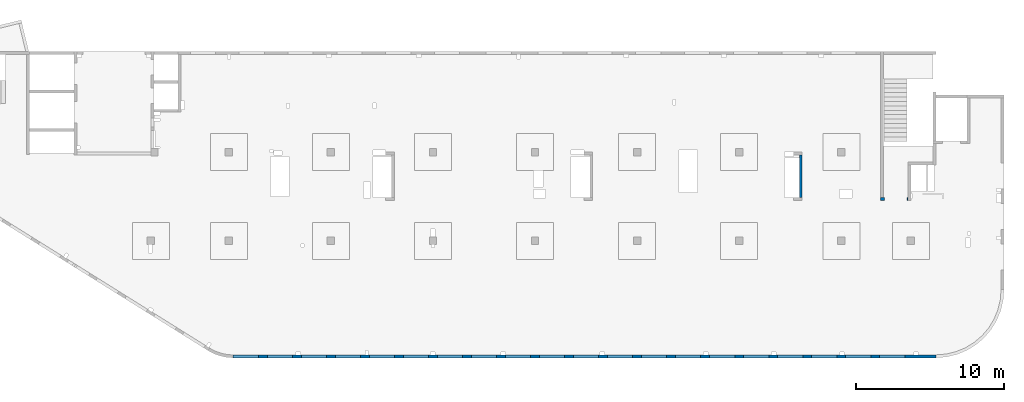
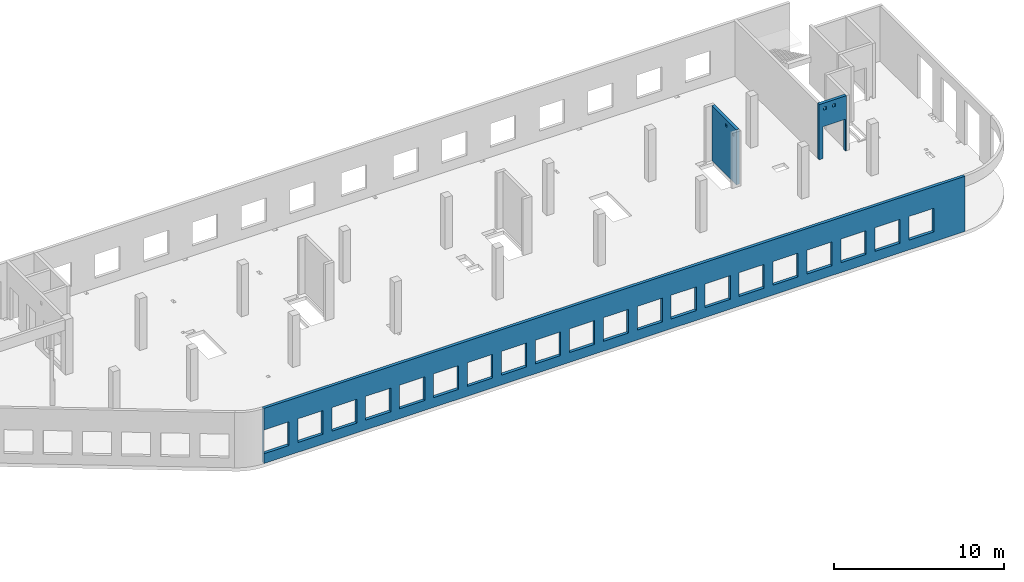
# One storey, part 6 of 7: 3 walls, 25 openings.
"""IFC4 building model written with IfcOpenShell, lengths in millimetres."""

from ifc_helpers import new_model, entity, si_unit, converted_unit, derived_unit, direction, frame, origin, place, context, subcontext, project, spatial, indexed_curve, outline, extrude, polygons, material, type_object, element, save


model = new_model("IFC4")

# Units and contexts
model_context = context("Model", 3, precision=0.01, world=origin(), true_north=direction((6.12303176911189e-17, 1.0)))
plan_context = context("Plan", 3, precision=0.01, world=origin(), true_north=direction((6.12303176911189e-17, 1.0)))
body_context = subcontext(model_context, "Body", "Model", "MODEL_VIEW")
ifc_project = project(units=[si_unit("LENGTHUNIT", "METRE", prefix="MILLI"), si_unit("AREAUNIT", "SQUARE_METRE"), si_unit("VOLUMEUNIT", "CUBIC_METRE"), converted_unit("PLANEANGLEUNIT", "DEGREE", entity("IfcRatioMeasure", 0.0174532925199433), si_unit("PLANEANGLEUNIT", "RADIAN"), dimensions=[0, 0, 0, 0, 0, 0, 0]), si_unit("MASSUNIT", "GRAM", prefix="KILO"), derived_unit("MASSDENSITYUNIT", [(si_unit("MASSUNIT", "GRAM", prefix="KILO"), 1), (si_unit("LENGTHUNIT", "METRE"), -3)]), derived_unit("MOMENTOFINERTIAUNIT", [(si_unit("LENGTHUNIT", "METRE"), 4)]), si_unit("TIMEUNIT", "SECOND"), si_unit("FREQUENCYUNIT", "HERTZ"), si_unit("THERMODYNAMICTEMPERATUREUNIT", "DEGREE_CELSIUS"), derived_unit("THERMALTRANSMITTANCEUNIT", [(si_unit("MASSUNIT", "GRAM", prefix="KILO"), 1), (si_unit("THERMODYNAMICTEMPERATUREUNIT", "KELVIN"), -1), (si_unit("TIMEUNIT", "SECOND"), -3)]), derived_unit("VOLUMETRICFLOWRATEUNIT", [(si_unit("LENGTHUNIT", "METRE"), 3), (si_unit("TIMEUNIT", "SECOND"), -1)]), derived_unit("MASSFLOWRATEUNIT", [(si_unit("MASSUNIT", "GRAM", prefix="KILO"), 1), (si_unit("TIMEUNIT", "SECOND"), -1)]), derived_unit("ROTATIONALFREQUENCYUNIT", [(si_unit("TIMEUNIT", "SECOND"), -1)]), si_unit("ELECTRICCURRENTUNIT", "AMPERE"), si_unit("ELECTRICVOLTAGEUNIT", "VOLT"), si_unit("POWERUNIT", "WATT"), si_unit("FORCEUNIT", "NEWTON", prefix="KILO"), si_unit("ILLUMINANCEUNIT", "LUX"), si_unit("LUMINOUSFLUXUNIT", "LUMEN"), si_unit("LUMINOUSINTENSITYUNIT", "CANDELA"), derived_unit("USERDEFINED", [(si_unit("MASSUNIT", "GRAM", prefix="KILO"), -1), (si_unit("LENGTHUNIT", "METRE"), -2), (si_unit("TIMEUNIT", "SECOND"), 3), (si_unit("LUMINOUSFLUXUNIT", "LUMEN"), 1)]), derived_unit("LINEARVELOCITYUNIT", [(si_unit("LENGTHUNIT", "METRE"), 1), (si_unit("TIMEUNIT", "SECOND"), -1)]), si_unit("PRESSUREUNIT", "PASCAL"), derived_unit("USERDEFINED", [(si_unit("LENGTHUNIT", "METRE"), -2), (si_unit("MASSUNIT", "GRAM", prefix="KILO"), 1), (si_unit("TIMEUNIT", "SECOND"), -2)]), derived_unit("LINEARFORCEUNIT", [(si_unit("MASSUNIT", "GRAM", prefix="KILO"), 1), (si_unit("LENGTHUNIT", "METRE"), 1), (si_unit("TIMEUNIT", "SECOND"), -2), (si_unit("LENGTHUNIT", "METRE"), -1)]), derived_unit("PLANARFORCEUNIT", [(si_unit("MASSUNIT", "GRAM", prefix="KILO"), 1), (si_unit("LENGTHUNIT", "METRE"), 1), (si_unit("TIMEUNIT", "SECOND"), -2), (si_unit("LENGTHUNIT", "METRE"), -2)])], contexts=[model_context, plan_context])

# Site, building, storey
site_placement = place(None, origin())
site = spatial("IfcSite", under=ifc_project, at=site_placement, CompositionType="ELEMENT")
building_placement = place(site_placement, origin())
building = spatial("IfcBuilding", under=site, at=building_placement, CompositionType="ELEMENT")
storey_placement = place(building_placement, frame((0.0, 0.0, 24000.0)))
storey = spatial("IfcBuildingStorey", under=building, at=storey_placement, Name="07", CompositionType="ELEMENT", Elevation=24000.0)

# Wall, openings
ifc_material = material()
wall_type = type_object("IfcWallType", Name=":ADSK_ 25_200", PredefinedType="STANDARD")
wall_1_placement = place(storey_placement, frame((67080.0, 10525.0, -150.0), z_axis=(0.0, 0.0, 1.0), x_axis=(-1.0, 0.0, 0.0)))
wall_1 = element("IfcWall", 1, at=wall_1_placement, inside=storey, type_object=wall_type, material=ifc_material, Name=":ADSK_ 25_200", ObjectType=":ADSK_ 25_200", PredefinedType="NOTDEFINED", context=body_context, shape_type="Tessellation", body=[
    polygons([(1849.99999999999, -100.000000000001, 3950.0), (1650.0, -100.000000000003, 3950.0), (-9.772240076716e-13, -100.000000000001, 3950.0), (-9.772240076716e-13, -100.000000000001, 0.0), (74.9999999999906, -100.000000000001, 0.0), (74.9999999999906, -100.000000000001, 2279.99999999804), (1575.0, -100.000000000001, 2279.99999999804), (1575.0, -100.000000000003, 0.0), (1650.0, -100.000000000003, 0.0), (1849.99999999999, -100.000000000001, 0.0), (744.999999999994, -100.000000000322, 3650.0), (945.000000000001, -100.000000000324, 3650.0), (945.000000000001, -100.000000000324, 3450.00000000001), (744.999999999994, -100.000000000322, 3450.00000000001), (1349.99999999998, -100.000000000322, 3650.0), (1549.99999999999, -100.000000000322, 3650.0), (1549.99999999999, -100.000000000322, 3450.00000000001), (1349.99999999998, -100.000000000322, 3450.00000000001), (-1.61109744921212e-12, 99.9999999999989, 3950.0), (1849.99999999999, 99.9999999999989, 3950.0), (1849.99999999999, 99.9999999999989, 0.0), (1575.0, 99.9999999999968, 0.0), (1575.0, 99.9999999999968, 2279.99999999804), (74.99999999999, 99.9999999999989, 2279.99999999804), (74.99999999999, 99.9999999999989, 0.0), (-1.61109744921212e-12, 99.9999999999989, 0.0), (945.0, 99.9999999999968, 3650.0), (744.999999999994, 99.9999999999989, 3650.0), (744.999999999994, 99.9999999999989, 3450.00000000001), (945.0, 99.9999999999968, 3450.00000000001), (1549.99999999999, 99.9999999999968, 3650.0), (1349.99999999998, 99.9999999999989, 3650.0), (1349.99999999998, 99.9999999999989, 3450.00000000001), (1549.99999999999, 99.9999999999968, 3450.00000000001)], [[[1, 2, 3, 4, 5, 6, 7, 8, 9, 10], [11, 12, 13, 14], [15, 16, 17, 18]], [[19, 20, 21, 22, 23, 24, 25, 26], [27, 28, 29, 30], [31, 32, 33, 34]], [[4, 26, 25, 5]], [[3, 2, 1, 20, 19]], [[4, 3, 19, 26]], [[1, 10, 21, 20]], [[12, 11, 28, 27]], [[12, 27, 30, 13]], [[13, 30, 29, 14]], [[28, 11, 14, 29]], [[16, 15, 32, 31]], [[16, 31, 34, 17]], [[17, 34, 33, 18]], [[32, 15, 18, 33]], [[6, 24, 23, 7]], [[7, 23, 22, 8]], [[24, 6, 5, 25]], [[21, 10, 9, 8, 22]]], closed=True),
])
placement_1 = place(wall_1_placement, frame((67080.0, 10525.0, 150.0), z_axis=(0.0, 0.0, 1.0), x_axis=(-1.0, 0.0, 0.0)))
element("IfcOpeningElement", 2, at=placement_1, cuts=wall_1, Name=":ADSK_ 25_200", PredefinedType="OPENING", context=body_context, shape_type="SweptSolid", body=[
    extrude(outline(indexed_curve([(-750.000000000003, -1139.99999999902), (749.999999999994, -1139.99999999902), (749.999999999994, 1139.99999999902), (-750.000000000003, 1139.99999999902), (-750.000000000003, -1139.99999999902)], self_intersect=False)), frame((66255.0, 10725.0, 990.0), z_axis=(0.0, -1.0, 0.0), x_axis=(-1.0, 0.0, 0.0)), (0.0, 0.0, 1.0), 400.000000001943),
])
element("IfcOpeningElement", 3, at=placement_1, cuts=wall_1, Name=":ADSK_ 25_200", PredefinedType="OPENING", context=body_context, shape_type="SweptSolid", body=[
    extrude(outline(indexed_curve([(-99.9999999999946, -99.9999999999946), (100.000000000003, -99.9999999999946), (100.000000000003, 99.9999999999903), (-99.9999999999946, 99.9999999999903), (-99.9999999999946, -99.9999999999946)], self_intersect=False)), frame((65630.0, 10625.0, 3400.0), z_axis=(0.0, -1.0, 0.0), x_axis=(-1.0, 0.0, 0.0)), (0.0, 0.0, 1.0), 200.000000000962),
])
element("IfcOpeningElement", 4, at=placement_1, cuts=wall_1, Name=":ADSK_ 25_200", PredefinedType="OPENING", context=body_context, shape_type="SweptSolid", body=[
    extrude(outline(indexed_curve([(-100.000000000003, -99.9999999999946), (99.9999999999946, -99.9999999999946), (99.9999999999946, 99.9999999999903), (-100.000000000003, 99.9999999999903), (-100.000000000003, -99.9999999999946)], self_intersect=False)), frame((66235.0, 10625.0, 3400.0), z_axis=(0.0, -1.0, 0.0), x_axis=(-1.0, 0.0, 0.0)), (0.0, 0.0, 1.0), 200.000000000962),
])

wall_2_placement = place(storey_placement, frame((68970.0, -100.0, -150.0), z_axis=(0.0, 0.0, 1.0), x_axis=(-1.0, 0.0, 0.0)))
wall_2 = element("IfcWall", 5, at=wall_2_placement, inside=storey, type_object=wall_type, material=ifc_material, Name=":ADSK_ 25_200", ObjectType=":ADSK_ 25_200", PredefinedType="NOTDEFINED", context=body_context, shape_type="Tessellation", body=[
    polygons([(8.66293717728731e-12, -100.0, 0.0), (47510.4829306172, -100.0, 0.0), (47510.4829306172, -100.0, 3950.0), (8.66293717728731e-12, -100.0, 3950.0), (1.42900165493394e-19, -100.0, 3200.0), (45800.0, -100.000000000321, 2400.0), (47500.0, -100.000000000321, 2400.0), (47500.0, -100.000000000321, 700.000000000014), (45800.0, -100.000000000321, 700.000000000014), (43500.0, -100.000000000321, 2400.0), (45200.0, -100.000000000321, 2400.0), (45200.0, -100.000000000321, 700.00000000001), (43500.0, -100.000000000321, 700.00000000001), (41200.0, -100.000000000321, 2400.0), (42900.0, -100.000000000321, 2400.0), (42900.0, -100.000000000321, 700.00000000001), (41200.0, -100.000000000321, 700.00000000001), (38900.0, -100.000000000321, 2400.0), (40600.0, -100.000000000321, 2400.0), (40600.0, -100.000000000321, 700.00000000001), (38900.0, -100.000000000321, 700.00000000001), (36600.0, -100.000000000321, 2400.0), (38300.0, -100.000000000321, 2400.0), (38300.0, -100.000000000321, 700.00000000001), (36600.0, -100.000000000321, 700.00000000001), (34300.0, -100.000000000321, 2400.0), (36000.0, -100.000000000321, 2400.0), (36000.0, -100.000000000321, 700.00000000001), (34300.0, -100.000000000321, 700.00000000001), (32000.0, -100.000000000321, 2400.0), (33700.0, -100.000000000321, 2400.0), (33700.0, -100.000000000321, 700.00000000001), (32000.0, -100.000000000321, 700.00000000001), (29700.0, -100.000000000321, 2400.0), (31400.0, -100.000000000321, 2400.0), (31400.0, -100.000000000321, 700.00000000001), (29700.0, -100.000000000321, 700.00000000001), (27400.0, -100.000000000321, 2400.0), (29100.0, -100.000000000321, 2400.0), (29100.0, -100.000000000321, 700.00000000001), (27400.0, -100.000000000321, 700.00000000001), (25100.0, -100.000000000321, 2400.0), (26800.0, -100.000000000321, 2400.0), (26800.0, -100.000000000321, 700.00000000001), (25100.0, -100.000000000321, 700.00000000001), (22800.0, -100.000000000321, 2400.0), (24500.0, -100.000000000321, 2400.0), (24500.0, -100.000000000321, 700.00000000001), (22800.0, -100.000000000321, 700.00000000001), (20500.0, -100.000000000321, 2400.0), (22200.0, -100.000000000321, 2400.0), (22200.0, -100.000000000321, 700.00000000001), (20500.0, -100.000000000321, 700.00000000001), (18200.0, -100.000000000321, 2400.0), (19900.0, -100.000000000321, 2400.0), (19900.0, -100.000000000321, 700.00000000001), (18200.0, -100.000000000321, 700.00000000001), (15900.0, -100.000000000321, 2400.0), (17600.0, -100.000000000321, 2400.0), (17600.0, -100.000000000321, 700.00000000001), (15900.0, -100.000000000321, 700.00000000001), (13600.0, -100.000000000321, 2400.0), (15300.0, -100.000000000321, 2400.0), (15300.0, -100.000000000321, 700.00000000001), (13600.0, -100.000000000321, 700.00000000001), (11300.0, -100.000000000321, 2400.0), (13000.0, -100.000000000321, 2400.0), (13000.0, -100.000000000321, 700.00000000001), (11300.0, -100.000000000321, 700.00000000001), (8999.99999999998, -100.000000000321, 2400.0), (10700.0, -100.000000000321, 2400.0), (10700.0, -100.000000000321, 700.00000000001), (8999.99999999998, -100.000000000321, 700.00000000001), (6699.99999999998, -100.000000000321, 2400.0), (8399.99999999997, -100.000000000321, 2400.0), (8399.99999999997, -100.000000000321, 700.00000000001), (6699.99999999998, -100.000000000321, 700.00000000001), (4399.99999999998, -100.000000000321, 2400.0), (6099.99999999997, -100.000000000321, 2400.0), (6099.99999999997, -100.000000000321, 700.00000000001), (4399.99999999998, -100.000000000321, 700.00000000001), (2099.99999999998, -100.000000000321, 2400.0), (3799.99999999998, -100.000000000321, 2400.0), (3799.99999999998, -100.000000000321, 700.00000000001), (2099.99999999998, -100.000000000321, 700.00000000001), (47510.4829306172, 100.0, 0.0), (8.01671852045731e-12, 100.0, 0.0), (-6.46218513929826e-13, 100.0, 3200.0), (8.01671852045731e-12, 100.0, 3950.0), (47510.4829306172, 100.0, 3950.0), (47500.0, 100.0, 2400.0), (45800.0, 100.0, 2400.0), (45800.0, 100.0, 700.00000000001), (47500.0, 100.0, 700.00000000001), (45200.0, 100.0, 2400.0), (43500.0, 100.0, 2400.0), (43500.0, 100.0, 700.00000000001), (45200.0, 100.0, 700.00000000001), (42900.0, 100.0, 2400.0), (41200.0, 100.0, 2400.0), (41200.0, 100.0, 700.00000000001), (42900.0, 100.0, 700.00000000001), (40600.0, 100.0, 2400.0), (38900.0, 100.0, 2400.0), (38900.0, 100.0, 700.00000000001), (40600.0, 100.0, 700.00000000001), (38300.0, 100.0, 2400.0), (36600.0, 100.0, 2400.0), (36600.0, 100.0, 700.00000000001), (38300.0, 100.0, 700.00000000001), (36000.0, 100.0, 2400.0), (34300.0, 100.0, 2400.0), (34300.0, 100.0, 700.00000000001), (36000.0, 100.0, 700.00000000001), (33700.0, 100.0, 2400.0), (32000.0, 100.0, 2400.0), (32000.0, 100.0, 700.00000000001), (33700.0, 100.0, 700.00000000001), (31400.0, 100.0, 2400.0), (29700.0, 100.0, 2400.0), (29700.0, 100.0, 700.00000000001), (31400.0, 100.0, 700.00000000001), (29100.0, 100.0, 2400.0), (27400.0, 100.0, 2400.0), (27400.0, 100.0, 700.00000000001), (29100.0, 100.0, 700.00000000001), (26800.0, 100.0, 2400.0), (25100.0, 100.0, 2400.0), (25100.0, 100.0, 700.00000000001), (26800.0, 100.0, 700.00000000001), (24500.0, 100.0, 2400.0), (22800.0, 100.0, 2400.0), (22800.0, 100.0, 700.00000000001), (24500.0, 100.0, 700.00000000001), (22200.0, 100.0, 2400.0), (20500.0, 100.0, 2400.0), (20500.0, 100.0, 700.00000000001), (22200.0, 100.0, 700.00000000001), (19900.0, 100.0, 2400.0), (18200.0, 100.0, 2400.0), (18200.0, 100.0, 700.00000000001), (19900.0, 100.0, 700.00000000001), (17600.0, 100.0, 2400.0), (15900.0, 100.0, 2400.0), (15900.0, 100.0, 700.00000000001), (17600.0, 100.0, 700.00000000001), (15300.0, 100.0, 2400.0), (13600.0, 100.0, 2400.0), (13600.0, 100.0, 700.00000000001), (15300.0, 100.0, 700.00000000001), (13000.0, 100.0, 2400.0), (11300.0, 100.0, 2400.0), (11300.0, 100.0, 700.00000000001), (13000.0, 100.0, 700.00000000001), (10700.0, 100.0, 2400.0), (8999.99999999998, 100.0, 2400.0), (8999.99999999998, 100.0, 700.00000000001), (10700.0, 100.0, 700.00000000001), (8399.99999999997, 100.0, 2400.0), (6699.99999999997, 100.0, 2400.0), (6699.99999999997, 100.0, 700.00000000001), (8399.99999999997, 100.0, 700.00000000001), (6099.99999999997, 100.0, 2400.0), (4399.99999999998, 100.0, 2400.0), (4399.99999999998, 100.0, 700.00000000001), (6099.99999999997, 100.0, 700.00000000001), (3799.99999999998, 100.0, 2400.0), (2099.99999999998, 100.0, 2400.0), (2099.99999999998, 100.0, 700.00000000001), (3799.99999999998, 100.0, 700.00000000001)], [[[1, 2, 3, 4, 5], [6, 7, 8, 9], [10, 11, 12, 13], [14, 15, 16, 17], [18, 19, 20, 21], [22, 23, 24, 25], [26, 27, 28, 29], [30, 31, 32, 33], [34, 35, 36, 37], [38, 39, 40, 41], [42, 43, 44, 45], [46, 47, 48, 49], [50, 51, 52, 53], [54, 55, 56, 57], [58, 59, 60, 61], [62, 63, 64, 65], [66, 67, 68, 69], [70, 71, 72, 73], [74, 75, 76, 77], [78, 79, 80, 81], [82, 83, 84, 85]], [[86, 87, 88, 89, 90], [91, 92, 93, 94], [95, 96, 97, 98], [99, 100, 101, 102], [103, 104, 105, 106], [107, 108, 109, 110], [111, 112, 113, 114], [115, 116, 117, 118], [119, 120, 121, 122], [123, 124, 125, 126], [127, 128, 129, 130], [131, 132, 133, 134], [135, 136, 137, 138], [139, 140, 141, 142], [143, 144, 145, 146], [147, 148, 149, 150], [151, 152, 153, 154], [155, 156, 157, 158], [159, 160, 161, 162], [163, 164, 165, 166], [167, 168, 169, 170]], [[2, 1, 87, 86]], [[3, 2, 86, 90]], [[4, 3, 90, 89]], [[1, 5, 4, 89, 88, 87]], [[91, 7, 6, 92]], [[7, 91, 94, 8]], [[8, 94, 93, 9]], [[92, 6, 9, 93]], [[11, 10, 96, 95]], [[11, 95, 98, 12]], [[12, 98, 97, 13]], [[96, 10, 13, 97]], [[15, 14, 100, 99]], [[15, 99, 102, 16]], [[16, 102, 101, 17]], [[100, 14, 17, 101]], [[19, 18, 104, 103]], [[19, 103, 106, 20]], [[20, 106, 105, 21]], [[104, 18, 21, 105]], [[23, 22, 108, 107]], [[23, 107, 110, 24]], [[24, 110, 109, 25]], [[108, 22, 25, 109]], [[27, 26, 112, 111]], [[27, 111, 114, 28]], [[28, 114, 113, 29]], [[112, 26, 29, 113]], [[31, 30, 116, 115]], [[31, 115, 118, 32]], [[32, 118, 117, 33]], [[116, 30, 33, 117]], [[35, 34, 120, 119]], [[35, 119, 122, 36]], [[36, 122, 121, 37]], [[120, 34, 37, 121]], [[39, 38, 124, 123]], [[39, 123, 126, 40]], [[40, 126, 125, 41]], [[124, 38, 41, 125]], [[43, 42, 128, 127]], [[43, 127, 130, 44]], [[44, 130, 129, 45]], [[128, 42, 45, 129]], [[47, 46, 132, 131]], [[47, 131, 134, 48]], [[48, 134, 133, 49]], [[132, 46, 49, 133]], [[51, 50, 136, 135]], [[51, 135, 138, 52]], [[52, 138, 137, 53]], [[136, 50, 53, 137]], [[55, 54, 140, 139]], [[55, 139, 142, 56]], [[56, 142, 141, 57]], [[140, 54, 57, 141]], [[59, 58, 144, 143]], [[59, 143, 146, 60]], [[60, 146, 145, 61]], [[144, 58, 61, 145]], [[63, 62, 148, 147]], [[63, 147, 150, 64]], [[64, 150, 149, 65]], [[148, 62, 65, 149]], [[67, 66, 152, 151]], [[67, 151, 154, 68]], [[68, 154, 153, 69]], [[152, 66, 69, 153]], [[71, 70, 156, 155]], [[71, 155, 158, 72]], [[72, 158, 157, 73]], [[156, 70, 73, 157]], [[75, 74, 160, 159]], [[75, 159, 162, 76]], [[76, 162, 161, 77]], [[160, 74, 77, 161]], [[79, 78, 164, 163]], [[79, 163, 166, 80]], [[80, 166, 165, 81]], [[164, 78, 81, 165]], [[83, 82, 168, 167]], [[83, 167, 170, 84]], [[84, 170, 169, 85]], [[168, 82, 85, 169]]], closed=True),
])
placement_2 = place(wall_2_placement, frame((68970.0, -100.0, 150.0), z_axis=(0.0, 0.0, 1.0), x_axis=(-1.0, 0.0, 0.0)))
element("IfcOpeningElement", 6, at=placement_2, cuts=wall_2, Name=":ADSK_ 25_200", PredefinedType="OPENING", context=body_context, shape_type="SweptSolid", body=[
    extrude(outline(indexed_curve([(-850.000000000002, -849.999999999993), (849.999999999997, -849.999999999993), (849.999999999997, 849.999999999993), (-850.000000000002, 849.999999999993), (-850.000000000002, -849.999999999993)], self_intersect=False)), frame((22320.0, 0.0, 1400.0), z_axis=(0.0, -1.0, 0.0), x_axis=(-1.0, 0.0, 0.0)), (0.0, 0.0, 1.0), 200.000000000962),
])
element("IfcOpeningElement", 7, at=placement_2, cuts=wall_2, Name=":ADSK_ 25_200", PredefinedType="OPENING", context=body_context, shape_type="SweptSolid", body=[
    extrude(outline(indexed_curve([(-849.999999999997, -849.999999999993), (850.000000000006, -849.999999999993), (850.000000000006, 849.999999999993), (-849.999999999997, 849.999999999993), (-849.999999999997, -849.999999999993)], self_intersect=False)), frame((66020.0, 0.0, 1400.0), z_axis=(0.0, -1.0, 0.0), x_axis=(-1.0, 0.0, 0.0)), (0.0, 0.0, 1.0), 200.000000000962),
])
element("IfcOpeningElement", 8, at=placement_2, cuts=wall_2, Name=":ADSK_ 25_200", PredefinedType="OPENING", context=body_context, shape_type="SweptSolid", body=[
    extrude(outline(indexed_curve([(-849.999999999997, -849.999999999993), (850.000000000006, -849.999999999993), (850.000000000006, 849.999999999993), (-849.999999999997, 849.999999999993), (-849.999999999997, -849.999999999993)], self_intersect=False)), frame((63720.0, 0.0, 1400.0), z_axis=(0.0, -1.0, 0.0), x_axis=(-1.0, 0.0, 0.0)), (0.0, 0.0, 1.0), 200.000000000962),
])
element("IfcOpeningElement", 9, at=placement_2, cuts=wall_2, Name=":ADSK_ 25_200", PredefinedType="OPENING", context=body_context, shape_type="SweptSolid", body=[
    extrude(outline(indexed_curve([(-849.999999999997, -849.999999999993), (850.000000000006, -849.999999999993), (850.000000000006, 849.999999999993), (-849.999999999997, 849.999999999993), (-849.999999999997, -849.999999999993)], self_intersect=False)), frame((61420.0, 0.0, 1400.0), z_axis=(0.0, -1.0, 0.0), x_axis=(-1.0, 0.0, 0.0)), (0.0, 0.0, 1.0), 200.000000000962),
])
element("IfcOpeningElement", 10, at=placement_2, cuts=wall_2, Name=":ADSK_ 25_200", PredefinedType="OPENING", context=body_context, shape_type="SweptSolid", body=[
    extrude(outline(indexed_curve([(-849.999999999997, -849.999999999993), (850.000000000006, -849.999999999993), (850.000000000006, 849.999999999993), (-849.999999999997, 849.999999999993), (-849.999999999997, -849.999999999993)], self_intersect=False)), frame((59120.0, 0.0, 1400.0), z_axis=(0.0, -1.0, 0.0), x_axis=(-1.0, 0.0, 0.0)), (0.0, 0.0, 1.0), 200.000000000962),
])
element("IfcOpeningElement", 11, at=placement_2, cuts=wall_2, Name=":ADSK_ 25_200", PredefinedType="OPENING", context=body_context, shape_type="SweptSolid", body=[
    extrude(outline(indexed_curve([(-849.999999999997, -849.999999999993), (850.000000000006, -849.999999999993), (850.000000000006, 849.999999999993), (-849.999999999997, 849.999999999993), (-849.999999999997, -849.999999999993)], self_intersect=False)), frame((56820.0, 0.0, 1400.0), z_axis=(0.0, -1.0, 0.0), x_axis=(-1.0, 0.0, 0.0)), (0.0, 0.0, 1.0), 200.000000000962),
])
element("IfcOpeningElement", 12, at=placement_2, cuts=wall_2, Name=":ADSK_ 25_200", PredefinedType="OPENING", context=body_context, shape_type="SweptSolid", body=[
    extrude(outline(indexed_curve([(-849.999999999997, -849.999999999993), (850.000000000006, -849.999999999993), (850.000000000006, 849.999999999993), (-849.999999999997, 849.999999999993), (-849.999999999997, -849.999999999993)], self_intersect=False)), frame((54520.0, 0.0, 1400.0), z_axis=(0.0, -1.0, 0.0), x_axis=(-1.0, 0.0, 0.0)), (0.0, 0.0, 1.0), 200.000000000962),
])
element("IfcOpeningElement", 13, at=placement_2, cuts=wall_2, Name=":ADSK_ 25_200", PredefinedType="OPENING", context=body_context, shape_type="SweptSolid", body=[
    extrude(outline(indexed_curve([(-849.999999999997, -849.999999999993), (850.000000000006, -849.999999999993), (850.000000000006, 849.999999999993), (-849.999999999997, 849.999999999993), (-849.999999999997, -849.999999999993)], self_intersect=False)), frame((52220.0, 0.0, 1400.0), z_axis=(0.0, -1.0, 0.0), x_axis=(-1.0, 0.0, 0.0)), (0.0, 0.0, 1.0), 200.000000000962),
])
element("IfcOpeningElement", 14, at=placement_2, cuts=wall_2, Name=":ADSK_ 25_200", PredefinedType="OPENING", context=body_context, shape_type="SweptSolid", body=[
    extrude(outline(indexed_curve([(-849.999999999997, -849.999999999993), (850.000000000006, -849.999999999993), (850.000000000006, 849.999999999993), (-849.999999999997, 849.999999999993), (-849.999999999997, -849.999999999993)], self_intersect=False)), frame((49920.0, 0.0, 1400.0), z_axis=(0.0, -1.0, 0.0), x_axis=(-1.0, 0.0, 0.0)), (0.0, 0.0, 1.0), 200.000000000962),
])
element("IfcOpeningElement", 15, at=placement_2, cuts=wall_2, Name=":ADSK_ 25_200", PredefinedType="OPENING", context=body_context, shape_type="SweptSolid", body=[
    extrude(outline(indexed_curve([(-849.999999999997, -849.999999999993), (850.000000000006, -849.999999999993), (850.000000000006, 849.999999999993), (-849.999999999997, 849.999999999993), (-849.999999999997, -849.999999999993)], self_intersect=False)), frame((47620.0, 0.0, 1400.0), z_axis=(0.0, -1.0, 0.0), x_axis=(-1.0, 0.0, 0.0)), (0.0, 0.0, 1.0), 200.000000000962),
])
element("IfcOpeningElement", 16, at=placement_2, cuts=wall_2, Name=":ADSK_ 25_200", PredefinedType="OPENING", context=body_context, shape_type="SweptSolid", body=[
    extrude(outline(indexed_curve([(-849.999999999997, -849.999999999993), (850.000000000006, -849.999999999993), (850.000000000006, 849.999999999993), (-849.999999999997, 849.999999999993), (-849.999999999997, -849.999999999993)], self_intersect=False)), frame((45320.0, 0.0, 1400.0), z_axis=(0.0, -1.0, 0.0), x_axis=(-1.0, 0.0, 0.0)), (0.0, 0.0, 1.0), 200.000000000962),
])
element("IfcOpeningElement", 17, at=placement_2, cuts=wall_2, Name=":ADSK_ 25_200", PredefinedType="OPENING", context=body_context, shape_type="SweptSolid", body=[
    extrude(outline(indexed_curve([(-849.999999999997, -849.999999999993), (850.000000000006, -849.999999999993), (850.000000000006, 849.999999999993), (-849.999999999997, 849.999999999993), (-849.999999999997, -849.999999999993)], self_intersect=False)), frame((43020.0, 0.0, 1400.0), z_axis=(0.0, -1.0, 0.0), x_axis=(-1.0, 0.0, 0.0)), (0.0, 0.0, 1.0), 200.000000000962),
])
element("IfcOpeningElement", 18, at=placement_2, cuts=wall_2, Name=":ADSK_ 25_200", PredefinedType="OPENING", context=body_context, shape_type="SweptSolid", body=[
    extrude(outline(indexed_curve([(-849.999999999997, -849.999999999993), (850.000000000006, -849.999999999993), (850.000000000006, 849.999999999993), (-849.999999999997, 849.999999999993), (-849.999999999997, -849.999999999993)], self_intersect=False)), frame((40720.0, 0.0, 1400.0), z_axis=(0.0, -1.0, 0.0), x_axis=(-1.0, 0.0, 0.0)), (0.0, 0.0, 1.0), 200.000000000962),
])
element("IfcOpeningElement", 19, at=placement_2, cuts=wall_2, Name=":ADSK_ 25_200", PredefinedType="OPENING", context=body_context, shape_type="SweptSolid", body=[
    extrude(outline(indexed_curve([(-849.999999999997, -849.999999999993), (850.000000000002, -849.999999999993), (850.000000000002, 849.999999999993), (-849.999999999997, 849.999999999993), (-849.999999999997, -849.999999999993)], self_intersect=False)), frame((38420.0, 0.0, 1400.0), z_axis=(0.0, -1.0, 0.0), x_axis=(-1.0, 0.0, 0.0)), (0.0, 0.0, 1.0), 200.000000000962),
])
element("IfcOpeningElement", 20, at=placement_2, cuts=wall_2, Name=":ADSK_ 25_200", PredefinedType="OPENING", context=body_context, shape_type="SweptSolid", body=[
    extrude(outline(indexed_curve([(-849.999999999997, -849.999999999993), (850.000000000002, -849.999999999993), (850.000000000002, 849.999999999993), (-849.999999999997, 849.999999999993), (-849.999999999997, -849.999999999993)], self_intersect=False)), frame((36120.0, 0.0, 1400.0), z_axis=(0.0, -1.0, 0.0), x_axis=(-1.0, 0.0, 0.0)), (0.0, 0.0, 1.0), 200.000000000962),
])
element("IfcOpeningElement", 21, at=placement_2, cuts=wall_2, Name=":ADSK_ 25_200", PredefinedType="OPENING", context=body_context, shape_type="SweptSolid", body=[
    extrude(outline(indexed_curve([(-849.999999999997, -849.999999999993), (850.000000000002, -849.999999999993), (850.000000000002, 849.999999999993), (-849.999999999997, 849.999999999993), (-849.999999999997, -849.999999999993)], self_intersect=False)), frame((33820.0, 0.0, 1400.0), z_axis=(0.0, -1.0, 0.0), x_axis=(-1.0, 0.0, 0.0)), (0.0, 0.0, 1.0), 200.000000000962),
])
element("IfcOpeningElement", 22, at=placement_2, cuts=wall_2, Name=":ADSK_ 25_200", PredefinedType="OPENING", context=body_context, shape_type="SweptSolid", body=[
    extrude(outline(indexed_curve([(-849.999999999997, -849.999999999993), (850.000000000002, -849.999999999993), (850.000000000002, 849.999999999993), (-849.999999999997, 849.999999999993), (-849.999999999997, -849.999999999993)], self_intersect=False)), frame((31520.0, 0.0, 1400.0), z_axis=(0.0, -1.0, 0.0), x_axis=(-1.0, 0.0, 0.0)), (0.0, 0.0, 1.0), 200.000000000962),
])
element("IfcOpeningElement", 23, at=placement_2, cuts=wall_2, Name=":ADSK_ 25_200", PredefinedType="OPENING", context=body_context, shape_type="SweptSolid", body=[
    extrude(outline(indexed_curve([(-850.000000000002, -849.999999999993), (849.999999999997, -849.999999999993), (849.999999999997, 849.999999999993), (-850.000000000002, 849.999999999993), (-850.000000000002, -849.999999999993)], self_intersect=False)), frame((29220.0, 0.0, 1400.0), z_axis=(0.0, -1.0, 0.0), x_axis=(-1.0, 0.0, 0.0)), (0.0, 0.0, 1.0), 200.000000000962),
])
element("IfcOpeningElement", 24, at=placement_2, cuts=wall_2, Name=":ADSK_ 25_200", PredefinedType="OPENING", context=body_context, shape_type="SweptSolid", body=[
    extrude(outline(indexed_curve([(-850.000000000002, -849.999999999993), (849.999999999997, -849.999999999993), (849.999999999997, 849.999999999993), (-850.000000000002, 849.999999999993), (-850.000000000002, -849.999999999993)], self_intersect=False)), frame((26920.0, 0.0, 1400.0), z_axis=(0.0, -1.0, 0.0), x_axis=(-1.0, 0.0, 0.0)), (0.0, 0.0, 1.0), 200.000000000962),
])
element("IfcOpeningElement", 25, at=placement_2, cuts=wall_2, Name=":ADSK_ 25_200", PredefinedType="OPENING", context=body_context, shape_type="SweptSolid", body=[
    extrude(outline(indexed_curve([(-850.000000000002, -849.999999999993), (849.999999999997, -849.999999999993), (849.999999999997, 849.999999999993), (-850.000000000002, 849.999999999993), (-850.000000000002, -849.999999999993)], self_intersect=False)), frame((24620.0, 0.0, 1400.0), z_axis=(0.0, -1.0, 0.0), x_axis=(-1.0, 0.0, 0.0)), (0.0, 0.0, 1.0), 200.000000000962),
])

wall_3_placement = place(storey_placement, frame((59830.0, 13500.0, -150.0), z_axis=(0.0, 0.0, 1.0), x_axis=(0.0, -1.0, 0.0)))
wall_3 = element("IfcWall", 26, at=wall_3_placement, inside=storey, type_object=wall_type, material=ifc_material, Name=":ADSK_ 25_200", ObjectType=":ADSK_ 25_200", PredefinedType="NOTDEFINED", context=body_context, shape_type="Tessellation", body=[
    polygons([(0.0, -99.999999999992, 0.0), (2875.00000000002, -99.9999999999833, 0.0), (2875.00000000002, -99.9999999999833, 3950.0), (205.000000000014, -99.9999999999913, 3950.0), (0.0, -99.999999999992, 3950.0), (2430.00000000002, -100.000000000002, 3500.0), (2630.00000000002, -100.000000000001, 3500.0), (2630.00000000002, -100.000000000001, 3300.00000000001), (2430.00000000002, -100.000000000002, 3300.00000000001), (1585.00000000001, -100.000000000005, 3650.0), (1785.00000000001, -100.000000000004, 3650.0), (1785.00000000001, -100.000000000004, 3450.00000000001), (1585.00000000001, -100.000000000005, 3450.00000000001), (2875.00000000002, 100.000000000006, 0.0), (0.0, 100.000000000006, 0.0), (0.0, 100.000000000006, 3950.0), (2875.00000000002, 100.000000000006, 3950.0), (2630.00000000002, 100.000000000326, 3500.0), (2430.00000000002, 100.000000000325, 3500.0), (2430.00000000002, 100.000000000325, 3300.00000000001), (2630.00000000002, 100.000000000326, 3300.00000000001), (1785.00000000002, 100.000000000323, 3650.0), (1585.00000000001, 100.000000000323, 3650.0), (1585.00000000001, 100.000000000323, 3450.00000000001), (1785.00000000001, 100.000000000323, 3450.00000000001)], [[[1, 2, 3, 4, 5], [6, 7, 8, 9], [10, 11, 12, 13]], [[14, 15, 16, 17], [18, 19, 20, 21], [22, 23, 24, 25]], [[2, 1, 15, 14]], [[1, 5, 16, 15]], [[3, 2, 14, 17]], [[17, 16, 5, 4, 3]], [[19, 18, 7, 6]], [[19, 6, 9, 20]], [[20, 9, 8, 21]], [[7, 18, 21, 8]], [[10, 23, 22, 11]], [[23, 10, 13, 24]], [[24, 13, 12, 25]], [[11, 22, 25, 12]]], closed=True),
])
placement_3 = place(wall_3_placement, frame((13500.0, -59830.0, 150.0), z_axis=(0.0, 0.0, 1.0), x_axis=(0.0, 1.0, 0.0)))
element("IfcOpeningElement", 27, at=placement_3, cuts=wall_3, Name=":ADSK_ 25_200", PredefinedType="OPENING", context=body_context, shape_type="SweptSolid", body=[
    extrude(outline(indexed_curve([(-99.9999999999903, -100.000000000001), (99.9999999999946, -100.000000000001), (99.9999999999946, 99.9999999999989), (-99.9999999999903, 99.9999999999989), (-99.9999999999903, -100.000000000001)], self_intersect=False)), frame((59730.0, 10970.0, 3250.0), z_axis=(1.0, 0.0, 0.0), x_axis=(0.0, 0.0, -1.0)), (0.0, 0.0, 1.0), 200.000000000968),
])
element("IfcOpeningElement", 28, at=placement_3, cuts=wall_3, Name=":ADSK_ 25_200", PredefinedType="OPENING", context=body_context, shape_type="SweptSolid", body=[
    extrude(outline(indexed_curve([(-99.9999999999946, -100.000000000001), (99.9999999999903, -100.000000000001), (99.9999999999903, 99.9999999999989), (-99.9999999999946, 99.9999999999989), (-99.9999999999946, -100.000000000001)], self_intersect=False)), frame((59730.0, 11815.0, 3400.0), z_axis=(1.0, 0.0, 0.0), x_axis=(0.0, 0.0, -1.0)), (0.0, 0.0, 1.0), 200.000000000968),
])

save(model, "model.ifc")
